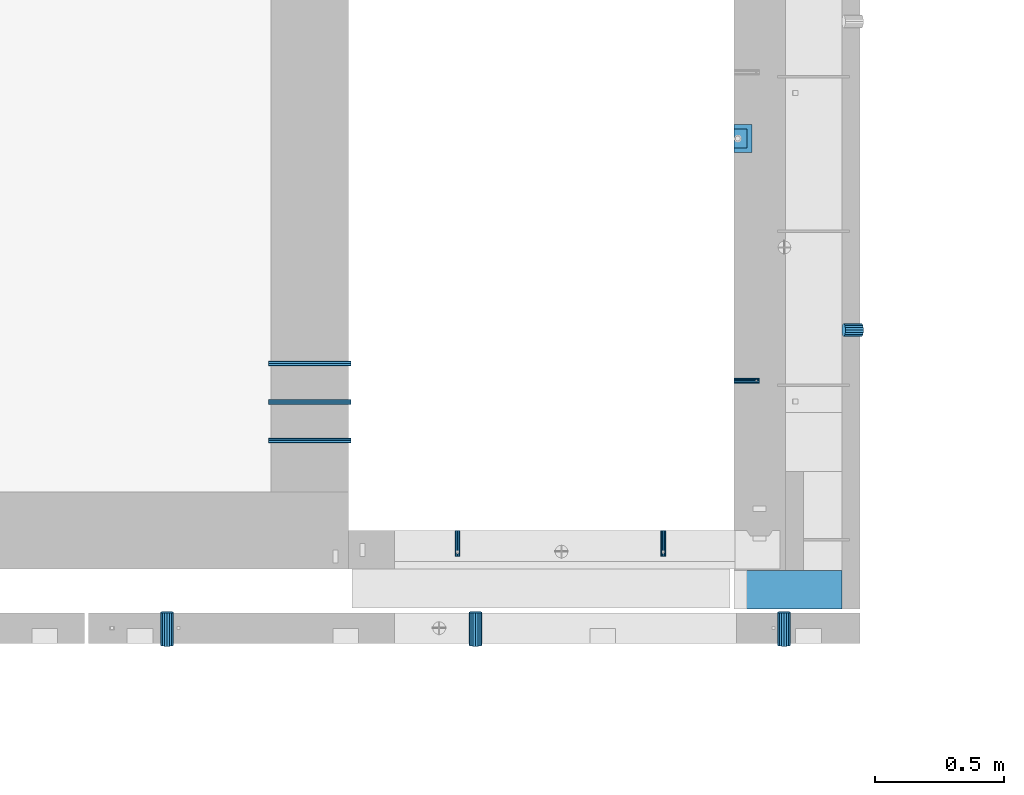
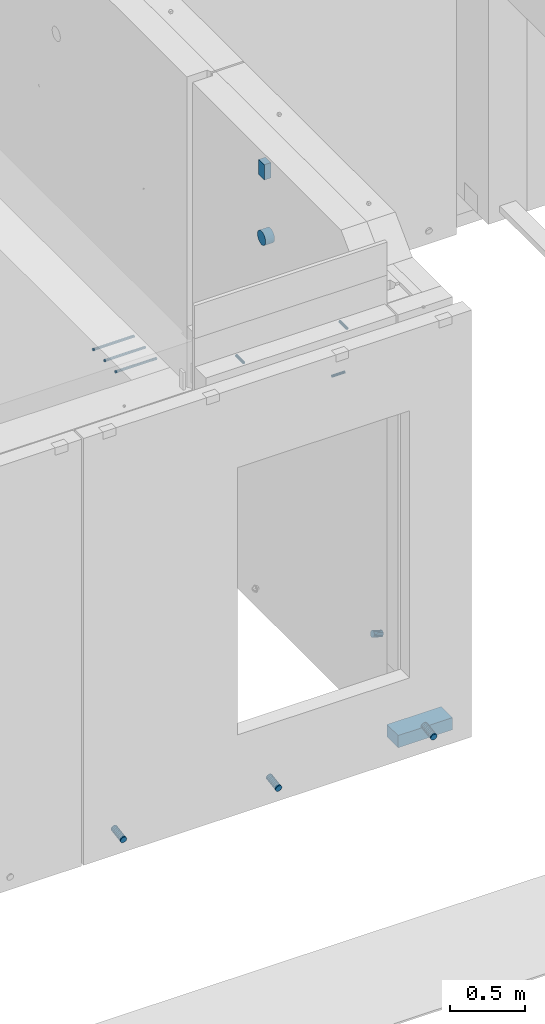
# One storey, part 89 of 264: 13 beams, 13 elements without a shape of their own.
"""IFC2X3 building model written with IfcOpenShell, lengths in millimetres."""

from ifc_helpers import new_model, si_unit, frame, origin_with_axes, place, context, subcontext, project, spatial, faceted_brep, material, type_object, element, aggregate, save


model = new_model("IFC2X3")

# Units and contexts
model_context = context("Model", 3, precision=1e-05, world=origin_with_axes())
body_context = subcontext(model_context, "Body", "Model", "MODEL_VIEW")
ifc_project = project(units=[si_unit("LENGTHUNIT", "METRE", prefix="MILLI"), si_unit("AREAUNIT", "SQUARE_METRE"), si_unit("VOLUMEUNIT", "CUBIC_METRE"), si_unit("MASSUNIT", "GRAM", prefix="KILO"), si_unit("TIMEUNIT", "SECOND"), si_unit("PLANEANGLEUNIT", "RADIAN"), si_unit("SOLIDANGLEUNIT", "STERADIAN"), si_unit("THERMODYNAMICTEMPERATUREUNIT", "DEGREE_CELSIUS"), si_unit("LUMINOUSINTENSITYUNIT", "LUMEN")], contexts=[model_context])

# Site, building, storey
site_placement = place(None, origin_with_axes())
site = spatial("IfcSite", under=ifc_project, at=site_placement, CompositionType="ELEMENT")
building_placement = place(site_placement, origin_with_axes())
building = spatial("IfcBuilding", under=site, at=building_placement, CompositionType="ELEMENT")
storey_placement = place(building_placement, origin_with_axes())
storey = spatial("IfcBuildingStorey", under=building, at=storey_placement, Name="K", CompositionType="ELEMENT", Elevation=0.0)

# Assemblies, beams
assembly_1_placement = place(storey_placement, origin_with_axes())
assembly_1 = element("IfcElementAssembly", 1, at=assembly_1_placement, inside=storey, AssemblyPlace="NOTDEFINED", PredefinedType="REINFORCEMENT_UNIT")
assembly_2_placement = place(assembly_1_placement, origin_with_axes())
assembly_2 = element("IfcElementAssembly", 2, at=assembly_2_placement, Name="Steel Assembly", AssemblyPlace="NOTDEFINED", PredefinedType="RIGID_FRAME")
ifc_material_1 = material(Name="STEEL/Steel_Undefined")
beam_type_1 = type_object("IfcBeamType", PredefinedType="NOTDEFINED")
beam_1_placement = place(assembly_2_placement, frame((17985.0020882577, 7999.99899559978, 81100.0), z_axis=(-1.0, 3.00000001838171e-08, 0.0), x_axis=(0.0, -1.0, 0.0)))
beam_1 = element("IfcBeam", 3, at=beam_1_placement, type_object=beam_type_1, material=ifc_material_1, Name="M16", context=body_context, shape_type="Brep", body=[
    faceted_brep([(0.0, -8.49999999999272, -1.45519152283669e-11), (0.0, -7.36121593215648, 4.24999999998545), (100.000000000262, -7.36121593215648, 4.24999999998545), (100.000000000262, -8.49999999999272, -1.45519152283669e-11), (0.0, -4.24999999998545, 7.36121593216376), (100.000000000262, -4.24999999998545, 7.36121593216376), (0.0, 1.45519152283669e-11, 8.49999999998545), (100.000000000262, 1.45519152283669e-11, 8.49999999998545), (0.0, 4.25000000001455, 7.36121593216376), (100.000000000262, 4.25000000001455, 7.36121593216376), (0.0, 7.36121593217104, 4.24999999998545), (100.000000000262, 7.36121593217104, 4.24999999998545), (0.0, 8.50000000000728, 0.0), (100.000000000262, 8.50000000000728, 0.0), (0.0, 7.36121593217104, -4.25000000001455), (100.000000000262, 7.36121593217104, -4.25000000001455), (0.0, 4.25000000000728, -7.36121593219286), (100.000000000262, 4.25000000000728, -7.36121593219286), (0.0, 7.27595761418343e-12, -8.5), (100.000000000262, 7.27595761418343e-12, -8.5), (0.0, -4.24999999999272, -7.36121593217831), (100.000000000262, -4.24999999999272, -7.36121593217831), (0.0, -7.36121593215648, -4.25), (100.000000000262, -7.36121593215648, -4.25), (0.0, -10.4999999999927, -1.45519152283669e-11), (0.0, -9.09326673972828, -5.25000000001455), (100.000000000262, -9.09326673972828, -5.25000000001455), (100.000000000262, -10.4999999999927, -1.45519152283669e-11), (0.0, -5.24999999998545, -9.09326673974283), (100.000000000262, -5.24999999998545, -9.09326673974283), (0.0, 7.27595761418343e-12, -10.5), (100.000000000262, 7.27595761418343e-12, -10.5), (0.0, 5.25000000001455, -9.09326673975738), (100.000000000262, 5.25000000001455, -9.09326673975738), (0.0, 9.09326673975011, -5.25000000001455), (100.000000000262, 9.09326673975011, -5.25000000001455), (0.0, 10.5000000000073, -1.45519152283669e-11), (100.000000000262, 10.5000000000073, -1.45519152283669e-11), (0.0, 9.09326673975011, 5.25), (100.000000000262, 9.09326673975011, 5.25), (0.0, 5.25000000000728, 9.09326673972828), (100.000000000262, 5.25000000000728, 9.09326673972828), (0.0, 1.45519152283669e-11, 10.4999999999854), (100.000000000262, 1.45519152283669e-11, 10.4999999999854), (0.0, -5.24999999999272, 9.09326673972828), (100.000000000262, -5.24999999999272, 9.09326673972828), (0.0, -9.09326673972828, 5.24999999998545), (100.000000000262, -9.09326673972828, 5.24999999998545)], [[[0, 1, 2, 3]], [[1, 4, 5, 2]], [[4, 6, 7, 5]], [[6, 8, 9, 7]], [[8, 10, 11, 9]], [[10, 12, 13, 11]], [[12, 14, 15, 13]], [[14, 16, 17, 15]], [[16, 18, 19, 17]], [[18, 20, 21, 19]], [[20, 22, 23, 21]], [[22, 0, 3, 23]], [[24, 25, 26, 27]], [[25, 28, 29, 26]], [[28, 30, 31, 29]], [[30, 32, 33, 31]], [[32, 34, 35, 33]], [[34, 36, 37, 35]], [[36, 38, 39, 37]], [[38, 40, 41, 39]], [[40, 42, 43, 41]], [[42, 44, 45, 43]], [[44, 46, 47, 45]], [[46, 24, 27, 47]], [[29, 31, 33, 35, 37, 39, 41, 43, 45, 47, 27, 26], [5, 7, 9, 11, 13, 15, 17, 19, 21, 23, 3, 2]], [[46, 44, 42, 40, 38, 36, 34, 32, 30, 28, 25, 24], [22, 20, 18, 16, 14, 12, 10, 8, 6, 4, 1, 0]]]),
])
aggregate(assembly_2, [beam_1])
assembly_3_placement = place(assembly_1_placement, origin_with_axes())
assembly_3 = element("IfcElementAssembly", 4, at=assembly_3_placement, Name="Steel Assembly", AssemblyPlace="NOTDEFINED", PredefinedType="RIGID_FRAME")
aggregate(assembly_1, [assembly_2, assembly_3])
beam_2_placement = place(assembly_3_placement, frame((17185.0020882577, 7999.99899559978, 81100.0), z_axis=(-1.0, 3.00000001838171e-08, 0.0), x_axis=(0.0, -1.0, 0.0)))
beam_2 = element("IfcBeam", 5, at=beam_2_placement, type_object=beam_type_1, material=ifc_material_1, Name="M16", context=body_context, shape_type="Brep", body=[
    faceted_brep([(0.0, -8.49999999999272, -1.45519152283669e-11), (0.0, -7.36121593215648, 4.24999999998545), (100.000000000262, -7.36121593215648, 4.24999999998545), (100.000000000262, -8.49999999999272, -1.45519152283669e-11), (0.0, -4.24999999998545, 7.36121593216376), (100.000000000262, -4.24999999998545, 7.36121593216376), (0.0, 1.45519152283669e-11, 8.49999999998545), (100.000000000262, 1.45519152283669e-11, 8.49999999998545), (0.0, 4.25000000001455, 7.36121593216376), (100.000000000262, 4.25000000001455, 7.36121593216376), (0.0, 7.36121593217104, 4.24999999998545), (100.000000000262, 7.36121593217104, 4.24999999998545), (0.0, 8.50000000000728, 0.0), (100.000000000262, 8.50000000000728, 0.0), (0.0, 7.36121593217104, -4.25000000001455), (100.000000000262, 7.36121593217104, -4.25000000001455), (0.0, 4.25000000000728, -7.36121593219286), (100.000000000262, 4.25000000000728, -7.36121593219286), (0.0, 7.27595761418343e-12, -8.5), (100.000000000262, 7.27595761418343e-12, -8.5), (0.0, -4.24999999999272, -7.36121593217831), (100.000000000262, -4.24999999999272, -7.36121593217831), (0.0, -7.36121593215648, -4.25), (100.000000000262, -7.36121593215648, -4.25), (0.0, -10.4999999999927, -1.45519152283669e-11), (0.0, -9.09326673972828, -5.25000000001455), (100.000000000262, -9.09326673972828, -5.25000000001455), (100.000000000262, -10.4999999999927, -1.45519152283669e-11), (0.0, -5.24999999998545, -9.09326673974283), (100.000000000262, -5.24999999998545, -9.09326673974283), (0.0, 7.27595761418343e-12, -10.5), (100.000000000262, 7.27595761418343e-12, -10.5), (0.0, 5.25000000001455, -9.09326673975738), (100.000000000262, 5.25000000001455, -9.09326673975738), (0.0, 9.09326673975011, -5.25000000001455), (100.000000000262, 9.09326673975011, -5.25000000001455), (0.0, 10.5000000000073, -1.45519152283669e-11), (100.000000000262, 10.5000000000073, -1.45519152283669e-11), (0.0, 9.09326673975011, 5.25), (100.000000000262, 9.09326673975011, 5.25), (0.0, 5.25000000000728, 9.09326673972828), (100.000000000262, 5.25000000000728, 9.09326673972828), (0.0, 1.45519152283669e-11, 10.4999999999854), (100.000000000262, 1.45519152283669e-11, 10.4999999999854), (0.0, -5.24999999999272, 9.09326673972828), (100.000000000262, -5.24999999999272, 9.09326673972828), (0.0, -9.09326673972828, 5.24999999998545), (100.000000000262, -9.09326673972828, 5.24999999998545)], [[[0, 1, 2, 3]], [[1, 4, 5, 2]], [[4, 6, 7, 5]], [[6, 8, 9, 7]], [[8, 10, 11, 9]], [[10, 12, 13, 11]], [[12, 14, 15, 13]], [[14, 16, 17, 15]], [[16, 18, 19, 17]], [[18, 20, 21, 19]], [[20, 22, 23, 21]], [[22, 0, 3, 23]], [[24, 25, 26, 27]], [[25, 28, 29, 26]], [[28, 30, 31, 29]], [[30, 32, 33, 31]], [[32, 34, 35, 33]], [[34, 36, 37, 35]], [[36, 38, 39, 37]], [[38, 40, 41, 39]], [[40, 42, 43, 41]], [[42, 44, 45, 43]], [[44, 46, 47, 45]], [[46, 24, 27, 47]], [[29, 31, 33, 35, 37, 39, 41, 43, 45, 47, 27, 26], [5, 7, 9, 11, 13, 15, 17, 19, 21, 23, 3, 2]], [[46, 44, 42, 40, 38, 36, 34, 32, 30, 28, 25, 24], [22, 20, 18, 16, 14, 12, 10, 8, 6, 4, 1, 0]]]),
])
aggregate(assembly_3, [beam_2])

# Assemblies, beam
assembly_4_placement = place(storey_placement, origin_with_axes())
assembly_4 = element("IfcElementAssembly", 6, at=assembly_4_placement, inside=storey, AssemblyPlace="NOTDEFINED", PredefinedType="REINFORCEMENT_UNIT")
assembly_5_placement = place(assembly_4_placement, origin_with_axes())
assembly_5 = element("IfcElementAssembly", 7, at=assembly_5_placement, Name="Steel Assembly", AssemblyPlace="NOTDEFINED", PredefinedType="RIGID_FRAME")
beam_3_placement = place(assembly_5_placement, frame((18260.0, 8583.09022014041, 80200.0), z_axis=(0.0, -1.0, 0.0), x_axis=(1.0, 0.0, 0.0)))
beam_3 = element("IfcBeam", 8, at=beam_3_placement, type_object=beam_type_1, material=ifc_material_1, Name="M16", context=body_context, shape_type="Brep", body=[
    faceted_brep([(0.0, -8.49999999999272, -1.45519152283669e-11), (0.0, -7.36121593215648, 4.24999999998545), (100.000000000262, -7.36121593215648, 4.24999999998545), (100.000000000262, -8.49999999999272, -1.45519152283669e-11), (0.0, -4.24999999998545, 7.36121593216376), (100.000000000262, -4.24999999998545, 7.36121593216376), (0.0, 1.45519152283669e-11, 8.49999999998545), (100.000000000262, 1.45519152283669e-11, 8.49999999998545), (0.0, 4.25000000001455, 7.36121593216376), (100.000000000262, 4.25000000001455, 7.36121593216376), (0.0, 7.36121593217104, 4.24999999998545), (100.000000000262, 7.36121593217104, 4.24999999998545), (0.0, 8.50000000000728, 0.0), (100.000000000262, 8.50000000000728, 0.0), (0.0, 7.36121593217104, -4.25000000001455), (100.000000000262, 7.36121593217104, -4.25000000001455), (0.0, 4.25000000000728, -7.36121593219286), (100.000000000262, 4.25000000000728, -7.36121593219286), (0.0, 7.27595761418343e-12, -8.5), (100.000000000262, 7.27595761418343e-12, -8.5), (0.0, -4.24999999999272, -7.36121593217831), (100.000000000262, -4.24999999999272, -7.36121593217831), (0.0, -7.36121593215648, -4.25), (100.000000000262, -7.36121593215648, -4.25), (0.0, -10.4999999999927, -1.45519152283669e-11), (0.0, -9.09326673972828, -5.25000000001455), (100.000000000262, -9.09326673972828, -5.25000000001455), (100.000000000262, -10.4999999999927, -1.45519152283669e-11), (0.0, -5.24999999998545, -9.09326673974283), (100.000000000262, -5.24999999998545, -9.09326673974283), (0.0, 7.27595761418343e-12, -10.5), (100.000000000262, 7.27595761418343e-12, -10.5), (0.0, 5.25000000001455, -9.09326673975738), (100.000000000262, 5.25000000001455, -9.09326673975738), (0.0, 9.09326673975011, -5.25000000001455), (100.000000000262, 9.09326673975011, -5.25000000001455), (0.0, 10.5000000000073, -1.45519152283669e-11), (100.000000000262, 10.5000000000073, -1.45519152283669e-11), (0.0, 9.09326673975011, 5.25), (100.000000000262, 9.09326673975011, 5.25), (0.0, 5.25000000000728, 9.09326673972828), (100.000000000262, 5.25000000000728, 9.09326673972828), (0.0, 1.45519152283669e-11, 10.4999999999854), (100.000000000262, 1.45519152283669e-11, 10.4999999999854), (0.0, -5.24999999999272, 9.09326673972828), (100.000000000262, -5.24999999999272, 9.09326673972828), (0.0, -9.09326673972828, 5.24999999998545), (100.000000000262, -9.09326673972828, 5.24999999998545)], [[[0, 1, 2, 3]], [[1, 4, 5, 2]], [[4, 6, 7, 5]], [[6, 8, 9, 7]], [[8, 10, 11, 9]], [[10, 12, 13, 11]], [[12, 14, 15, 13]], [[14, 16, 17, 15]], [[16, 18, 19, 17]], [[18, 20, 21, 19]], [[20, 22, 23, 21]], [[22, 0, 3, 23]], [[24, 25, 26, 27]], [[25, 28, 29, 26]], [[28, 30, 31, 29]], [[30, 32, 33, 31]], [[32, 34, 35, 33]], [[34, 36, 37, 35]], [[36, 38, 39, 37]], [[38, 40, 41, 39]], [[40, 42, 43, 41]], [[42, 44, 45, 43]], [[44, 46, 47, 45]], [[46, 24, 27, 47]], [[29, 31, 33, 35, 37, 39, 41, 43, 45, 47, 27, 26], [5, 7, 9, 11, 13, 15, 17, 19, 21, 23, 3, 2]], [[46, 44, 42, 40, 38, 36, 34, 32, 30, 28, 25, 24], [22, 20, 18, 16, 14, 12, 10, 8, 6, 4, 1, 0]]]),
])
aggregate(assembly_5, [beam_3])

# Assembly, beam
assembly_6_placement = place(storey_placement, origin_with_axes())
assembly_6 = element("IfcElementAssembly", 9, at=assembly_6_placement, inside=storey, Name="Steel Assembly", AssemblyPlace="NOTDEFINED", PredefinedType="NOTDEFINED")
ifc_material_2 = material()
beam_type_2 = type_object("IfcBeamType", Name="D20", PredefinedType="NOTDEFINED")
beam_4_placement = place(assembly_6_placement, frame((16450.0002273917, 8650.0001129508, 81010.0), z_axis=(0.0, 0.0, 1.0), x_axis=(1.0, 0.0, 0.0)))
beam_4 = element("IfcBeam", 10, at=beam_4_placement, type_object=beam_type_2, material=ifc_material_2, ObjectType="D20", context=body_context, shape_type="Brep", body=[
    faceted_brep([(0.0, -10.0, 0.0), (-4.19531716033816e-08, -7.07106781186667, -7.07106781187031), (320.000093691564, -7.07106781186485, -7.07106781186303), (320.000093691564, -10.0, 0.0), (0.0, 0.0, -10.0), (320.000093691564, 0.0, -10.0), (4.196772351861e-08, 7.07106781186303, -7.07106781186667), (320.000093691564, 7.07106781186485, -7.07106781186303), (0.0, 10.0, 0.0), (320.000093691564, 10.0, 0.0), (4.196772351861e-08, 7.07106781185939, 7.07106781185939), (320.000093691564, 7.07106781186485, 7.07106781186303), (0.0, 0.0, 10.0), (320.000093691564, 0.0, 10.0), (-4.19531716033816e-08, -7.07106781187031, 7.07106781185939), (320.000093691564, -7.07106781186485, 7.07106781186303)], [[[0, 1, 2, 3]], [[1, 4, 5, 2]], [[4, 6, 7, 5]], [[6, 8, 9, 7]], [[8, 10, 11, 9]], [[10, 12, 13, 11]], [[12, 14, 15, 13]], [[14, 0, 3, 15]], [[5, 7, 9, 11, 13, 15, 3, 2]], [[14, 12, 10, 8, 6, 4, 1, 0]]]),
])
aggregate(assembly_6, [beam_4])

assembly_7_placement = place(storey_placement, origin_with_axes())
assembly_7 = element("IfcElementAssembly", 11, at=assembly_7_placement, inside=storey, Name="Steel Assembly", AssemblyPlace="NOTDEFINED", PredefinedType="NOTDEFINED")
beam_5_placement = place(assembly_7_placement, frame((16450.0002273917, 8500.0001129508, 81010.0), z_axis=(0.0, 0.0, 1.0), x_axis=(1.0, 0.0, 0.0)))
beam_5 = element("IfcBeam", 12, at=beam_5_placement, type_object=beam_type_2, material=ifc_material_2, ObjectType="D20", context=body_context, shape_type="Brep", body=[
    faceted_brep([(0.0, -10.0, 0.0), (-4.19531716033816e-08, -7.07106781186667, -7.07106781187031), (320.000093691564, -7.07106781186485, -7.07106781186303), (320.000093691564, -10.0, 0.0), (0.0, 0.0, -10.0), (320.000093691564, 0.0, -10.0), (4.196772351861e-08, 7.07106781186303, -7.07106781186667), (320.000093691564, 7.07106781186485, -7.07106781186303), (0.0, 10.0, 0.0), (320.000093691564, 10.0, 0.0), (4.196772351861e-08, 7.07106781185939, 7.07106781185939), (320.000093691564, 7.07106781186485, 7.07106781186303), (0.0, 0.0, 10.0), (320.000093691564, 0.0, 10.0), (-4.19531716033816e-08, -7.07106781187031, 7.07106781185939), (320.000093691564, -7.07106781186485, 7.07106781186303)], [[[0, 1, 2, 3]], [[1, 4, 5, 2]], [[4, 6, 7, 5]], [[6, 8, 9, 7]], [[8, 10, 11, 9]], [[10, 12, 13, 11]], [[12, 14, 15, 13]], [[14, 0, 3, 15]], [[5, 7, 9, 11, 13, 15, 3, 2]], [[14, 12, 10, 8, 6, 4, 1, 0]]]),
])
aggregate(assembly_7, [beam_5])

assembly_8_placement = place(storey_placement, origin_with_axes())
assembly_8 = element("IfcElementAssembly", 13, at=assembly_8_placement, inside=storey, Name="Steel Assembly", AssemblyPlace="NOTDEFINED", PredefinedType="NOTDEFINED")
beam_6_placement = place(assembly_8_placement, frame((16450.0002273917, 8350.0001129508, 81010.0), z_axis=(0.0, 0.0, 1.0), x_axis=(1.0, 0.0, 0.0)))
beam_6 = element("IfcBeam", 14, at=beam_6_placement, type_object=beam_type_2, material=ifc_material_2, ObjectType="D20", context=body_context, shape_type="Brep", body=[
    faceted_brep([(0.0, -10.0, 0.0), (-4.19531716033816e-08, -7.07106781186667, -7.07106781187031), (320.000093691564, -7.07106781186485, -7.07106781186303), (320.000093691564, -10.0, 0.0), (0.0, 0.0, -10.0), (320.000093691564, 0.0, -10.0), (4.196772351861e-08, 7.07106781186303, -7.07106781186667), (320.000093691564, 7.07106781186485, -7.07106781186303), (0.0, 10.0, 0.0), (320.000093691564, 10.0, 0.0), (4.196772351861e-08, 7.07106781185939, 7.07106781185939), (320.000093691564, 7.07106781186485, 7.07106781186303), (0.0, 0.0, 10.0), (320.000093691564, 0.0, 10.0), (-4.19531716033816e-08, -7.07106781187031, 7.07106781185939), (320.000093691564, -7.07106781186485, 7.07106781186303)], [[[0, 1, 2, 3]], [[1, 4, 5, 2]], [[4, 6, 7, 5]], [[6, 8, 9, 7]], [[8, 10, 11, 9]], [[10, 12, 13, 11]], [[12, 14, 15, 13]], [[14, 0, 3, 15]], [[5, 7, 9, 11, 13, 15, 3, 2]], [[14, 12, 10, 8, 6, 4, 1, 0]]]),
])
aggregate(assembly_8, [beam_6])

# Beam
ifc_material_3 = material()
beam_type_3 = type_object("IfcBeamType", Name="D110", PredefinedType="NOTDEFINED")
beam_7_placement = place(assembly_4_placement, frame((18260.0, 9525.00030504026, 80760.0), z_axis=(0.0, 0.0, 1.0), x_axis=(1.0, 0.0, 0.0)))
beam_7 = element("IfcBeam", 15, at=beam_7_placement, type_object=beam_type_3, material=ifc_material_3, ObjectType="D110", context=body_context, shape_type="Brep", body=[
    faceted_brep([(0.0, -55.0, 0.0), (0.0, -52.3081083962352, -16.9959346906253), (70.0, -52.3081083962352, -16.9959346906253), (70.0, -55.0, 0.0), (0.0, -44.4959346906217, -32.328188876083), (70.0, -44.4959346906217, -32.328188876083), (0.0, -32.3281888760866, -44.4959346906253), (70.0, -32.3281888760866, -44.4959346906253), (0.0, -16.9959346906217, -52.3081083962315), (70.0, -16.9959346906217, -52.3081083962315), (0.0, 0.0, -55.0), (70.0, 0.0, -55.0), (0.0, 16.9959346906217, -52.3081083962315), (70.0, 16.9959346906217, -52.3081083962315), (0.0, 32.3281888760866, -44.4959346906253), (70.0, 32.3281888760866, -44.4959346906253), (0.0, 44.4959346906217, -32.328188876083), (70.0, 44.4959346906217, -32.328188876083), (0.0, 52.3081083962352, -16.9959346906253), (70.0, 52.3081083962352, -16.9959346906253), (0.0, 55.0, 0.0), (70.0, 55.0, 0.0), (0.0, 52.3081083962352, 16.9959346906253), (70.0, 52.3081083962352, 16.9959346906253), (0.0, 44.4959346906217, 32.328188876083), (70.0, 44.4959346906217, 32.328188876083), (0.0, 32.3281888760866, 44.4959346906253), (70.0, 32.3281888760866, 44.4959346906253), (0.0, 16.9959346906217, 52.3081083962315), (70.0, 16.9959346906217, 52.3081083962315), (0.0, 0.0, 55.0), (70.0, 0.0, 55.0), (0.0, -16.9959346906217, 52.3081083962315), (70.0, -16.9959346906217, 52.3081083962315), (0.0, -32.3281888760866, 44.4959346906253), (70.0, -32.3281888760866, 44.4959346906253), (0.0, -44.4959346906217, 32.328188876083), (70.0, -44.4959346906217, 32.328188876083), (0.0, -52.3081083962352, 16.9959346906253), (70.0, -52.3081083962352, 16.9959346906253)], [[[0, 1, 2, 3]], [[1, 4, 5, 2]], [[4, 6, 7, 5]], [[6, 8, 9, 7]], [[8, 10, 11, 9]], [[10, 12, 13, 11]], [[12, 14, 15, 13]], [[14, 16, 17, 15]], [[16, 18, 19, 17]], [[18, 20, 21, 19]], [[20, 22, 23, 21]], [[22, 24, 25, 23]], [[24, 26, 27, 25]], [[26, 28, 29, 27]], [[28, 30, 31, 29]], [[30, 32, 33, 31]], [[32, 34, 35, 33]], [[34, 36, 37, 35]], [[36, 38, 39, 37]], [[38, 0, 3, 39]], [[5, 7, 9, 11, 13, 15, 17, 19, 21, 23, 25, 27, 29, 31, 33, 35, 37, 39, 3, 2]], [[38, 36, 34, 32, 30, 28, 26, 24, 22, 20, 18, 16, 14, 12, 10, 8, 6, 4, 1, 0]]]),
])

beam_type_4 = type_object("IfcBeamType", Name="125X50", PredefinedType="NOTDEFINED")
beam_8_placement = place(assembly_4_placement, frame((18285.0, 9487.50202507202, 81317.5), z_axis=(0.0, 0.0, 1.0), x_axis=(0.0, 1.0, 0.0)))
beam_8 = element("IfcBeam", 16, at=beam_8_placement, type_object=beam_type_4, material=ifc_material_3, Name="WM1", ObjectType="125X50", context=body_context, shape_type="Brep", body=[
    faceted_brep([(0.0, 25.0, -62.5), (0.0, 25.0, 62.5), (75.0, 25.0, 62.5), (75.0, 25.0, -62.5), (0.0, -25.0, 62.5), (75.0, -25.0, 62.5), (0.0, -25.0, -62.5), (75.0, -25.0, -62.5)], [[[0, 1, 2, 3]], [[1, 4, 5, 2]], [[4, 6, 7, 5]], [[6, 0, 3, 7]], [[5, 7, 3, 2]], [[0, 6, 4, 1]]]),
])

# Assemblies, beams
assembly_9_placement = place(storey_placement, origin_with_axes())
assembly_9 = element("IfcElementAssembly", 17, at=assembly_9_placement, inside=storey, AssemblyPlace="NOTDEFINED", PredefinedType="REINFORCEMENT_UNIT")
assembly_10_placement = place(assembly_9_placement, origin_with_axes())
assembly_10 = element("IfcElementAssembly", 18, at=assembly_10_placement, Name="Steel Assembly", AssemblyPlace="NOTDEFINED", PredefinedType="NOTDEFINED")
ifc_material_4 = material()
beam_type_5 = type_object("IfcBeamType", Name="D50", PredefinedType="NOTDEFINED")
beam_9_placement = place(assembly_10_placement, frame((18455.0000002562, 7682.52585845164, 77824.7042173487), z_axis=(1.0, 0.0, 0.0), x_axis=(5.70000016371802e-08, -0.988168693923421, -0.1533708979881)))
beam_9 = element("IfcBeam", 19, at=beam_9_placement, type_object=beam_type_5, material=ifc_material_4, ObjectType="D50", context=body_context, shape_type="Brep", body=[
    faceted_brep([(0.0, -25.0, 0.0), (-3.63797880709171e-12, -23.0969883127837, -9.56708580912891), (130.402835998197, -23.0969883127691, -9.56708580912164), (130.402836001198, -25.0, 0.0), (-3.63797880709171e-12, -17.6776695296576, -17.6776695296649), (130.402835995654, -17.6776695296576, -17.6776695296612), (-1.09139364212751e-11, -9.56708580913255, -23.0969883127837), (130.402835993955, -9.567085809118, -23.0969883127764), (-1.09139364212751e-11, 0.0, -25.0), (130.402835993358, 0.0, -24.9999999999964), (-1.09139364212751e-11, 9.56708580913255, -23.0969883127837), (130.402835993951, 9.56708580913255, -23.09698831278), (-3.63797880709171e-12, 17.6776695296576, -17.6776695296649), (130.402835995654, 17.6776695296721, -17.6776695296612), (-3.63797880709171e-12, 23.0969883127837, -9.56708580912891), (130.402835998197, 23.0969883127837, -9.56708580912527), (0.0, 25.0, 0.0), (130.402836001202, 25.0, 7.27595761418343e-12), (7.27595761418343e-12, 23.0969883127837, 9.56708580912891), (130.402836004203, 23.0969883127982, 9.56708580913255), (7.27595761418343e-12, 17.6776695296576, 17.6776695296649), (130.402836006746, 17.6776695296721, 17.6776695296685), (1.45519152283669e-11, 9.56708580913255, 23.0969883127837), (130.402836008445, 9.56708580913255, 23.0969883127837), (1.09139364212751e-11, 0.0, 25.0), (130.402836009045, 1.45519152283669e-11, 25.0000000000036), (1.45519152283669e-11, -9.56708580913255, 23.0969883127837), (130.402836008449, -9.567085809118, 23.0969883127873), (7.27595761418343e-12, -17.6776695296576, 17.6776695296649), (130.402836006746, -17.6776695296576, 17.6776695296685), (7.27595761418343e-12, -23.0969883127837, 9.56708580912891), (130.402836004199, -23.0969883127837, 9.56708580913255)], [[[0, 1, 2, 3]], [[1, 4, 5, 2]], [[4, 6, 7, 5]], [[6, 8, 9, 7]], [[8, 10, 11, 9]], [[10, 12, 13, 11]], [[12, 14, 15, 13]], [[14, 16, 17, 15]], [[16, 18, 19, 17]], [[18, 20, 21, 19]], [[20, 22, 23, 21]], [[22, 24, 25, 23]], [[24, 26, 27, 25]], [[26, 28, 29, 27]], [[28, 30, 31, 29]], [[30, 0, 3, 31]], [[5, 7, 9, 11, 13, 15, 17, 19, 21, 23, 25, 27, 29, 31, 3, 2]], [[30, 28, 26, 24, 22, 20, 18, 16, 14, 12, 10, 8, 6, 4, 1, 0]]]),
])
aggregate(assembly_10, [beam_9])
assembly_11_placement = place(assembly_9_placement, origin_with_axes())
assembly_11 = element("IfcElementAssembly", 20, at=assembly_11_placement, Name="Steel Assembly", AssemblyPlace="NOTDEFINED", PredefinedType="NOTDEFINED")
beam_10_placement = place(assembly_11_placement, frame((16055.0000002562, 7682.52585845164, 77824.7042173487), z_axis=(1.0, 0.0, 0.0), x_axis=(5.70000016371802e-08, -0.988168693923421, -0.1533708979881)))
beam_10 = element("IfcBeam", 21, at=beam_10_placement, type_object=beam_type_5, material=ifc_material_4, ObjectType="D50", context=body_context, shape_type="Brep", body=[
    faceted_brep([(0.0, -25.0, 0.0), (-3.63797880709171e-12, -23.0969883127837, -9.56708580912891), (130.402835998197, -23.0969883127691, -9.56708580912164), (130.402836001198, -25.0, 0.0), (-3.63797880709171e-12, -17.6776695296576, -17.6776695296649), (130.402835995654, -17.6776695296576, -17.6776695296612), (-1.09139364212751e-11, -9.56708580913255, -23.0969883127837), (130.402835993955, -9.567085809118, -23.0969883127764), (-1.09139364212751e-11, 0.0, -25.0), (130.402835993358, 0.0, -24.9999999999964), (-1.09139364212751e-11, 9.56708580913255, -23.0969883127837), (130.402835993951, 9.56708580913255, -23.09698831278), (-3.63797880709171e-12, 17.6776695296576, -17.6776695296649), (130.402835995654, 17.6776695296721, -17.6776695296612), (-3.63797880709171e-12, 23.0969883127837, -9.56708580912891), (130.402835998197, 23.0969883127837, -9.56708580912527), (0.0, 25.0, 0.0), (130.402836001202, 25.0, 7.27595761418343e-12), (7.27595761418343e-12, 23.0969883127837, 9.56708580912891), (130.402836004203, 23.0969883127982, 9.56708580913255), (7.27595761418343e-12, 17.6776695296576, 17.6776695296649), (130.402836006746, 17.6776695296721, 17.6776695296685), (1.45519152283669e-11, 9.56708580913255, 23.0969883127837), (130.402836008445, 9.56708580913255, 23.0969883127837), (1.09139364212751e-11, 0.0, 25.0), (130.402836009045, 1.45519152283669e-11, 25.0000000000036), (1.45519152283669e-11, -9.56708580913255, 23.0969883127837), (130.402836008449, -9.567085809118, 23.0969883127873), (7.27595761418343e-12, -17.6776695296576, 17.6776695296649), (130.402836006746, -17.6776695296576, 17.6776695296685), (7.27595761418343e-12, -23.0969883127837, 9.56708580912891), (130.402836004199, -23.0969883127837, 9.56708580913255)], [[[0, 1, 2, 3]], [[1, 4, 5, 2]], [[4, 6, 7, 5]], [[6, 8, 9, 7]], [[8, 10, 11, 9]], [[10, 12, 13, 11]], [[12, 14, 15, 13]], [[14, 16, 17, 15]], [[16, 18, 19, 17]], [[18, 20, 21, 19]], [[20, 22, 23, 21]], [[22, 24, 25, 23]], [[24, 26, 27, 25]], [[26, 28, 29, 27]], [[28, 30, 31, 29]], [[30, 0, 3, 31]], [[5, 7, 9, 11, 13, 15, 17, 19, 21, 23, 25, 27, 29, 31, 3, 2]], [[30, 28, 26, 24, 22, 20, 18, 16, 14, 12, 10, 8, 6, 4, 1, 0]]]),
])
aggregate(assembly_11, [beam_10])
assembly_12_placement = place(assembly_9_placement, origin_with_axes())
assembly_12 = element("IfcElementAssembly", 22, at=assembly_12_placement, Name="Steel Assembly", AssemblyPlace="NOTDEFINED", PredefinedType="NOTDEFINED")
aggregate(assembly_9, [assembly_10, assembly_11, assembly_12])
beam_11_placement = place(assembly_12_placement, frame((17255.0000002562, 7682.52585845164, 77824.7042173487), z_axis=(1.0, 0.0, 0.0), x_axis=(5.70000016371802e-08, -0.988168693923421, -0.1533708979881)))
beam_11 = element("IfcBeam", 23, at=beam_11_placement, type_object=beam_type_5, material=ifc_material_4, ObjectType="D50", context=body_context, shape_type="Brep", body=[
    faceted_brep([(0.0, -25.0, 0.0), (-3.63797880709171e-12, -23.0969883127837, -9.56708580912891), (130.402835998197, -23.0969883127691, -9.56708580912164), (130.402836001198, -25.0, 0.0), (-3.63797880709171e-12, -17.6776695296576, -17.6776695296649), (130.402835995654, -17.6776695296576, -17.6776695296612), (-1.09139364212751e-11, -9.56708580913255, -23.0969883127837), (130.402835993955, -9.567085809118, -23.0969883127764), (-1.09139364212751e-11, 0.0, -25.0), (130.402835993358, 0.0, -24.9999999999964), (-1.09139364212751e-11, 9.56708580913255, -23.0969883127837), (130.402835993951, 9.56708580913255, -23.09698831278), (-3.63797880709171e-12, 17.6776695296576, -17.6776695296649), (130.402835995654, 17.6776695296721, -17.6776695296612), (-3.63797880709171e-12, 23.0969883127837, -9.56708580912891), (130.402835998197, 23.0969883127837, -9.56708580912527), (0.0, 25.0, 0.0), (130.402836001202, 25.0, 7.27595761418343e-12), (7.27595761418343e-12, 23.0969883127837, 9.56708580912891), (130.402836004203, 23.0969883127982, 9.56708580913255), (7.27595761418343e-12, 17.6776695296576, 17.6776695296649), (130.402836006746, 17.6776695296721, 17.6776695296685), (1.45519152283669e-11, 9.56708580913255, 23.0969883127837), (130.402836008445, 9.56708580913255, 23.0969883127837), (1.09139364212751e-11, 0.0, 25.0), (130.402836009045, 1.45519152283669e-11, 25.0000000000036), (1.45519152283669e-11, -9.56708580913255, 23.0969883127837), (130.402836008449, -9.567085809118, 23.0969883127873), (7.27595761418343e-12, -17.6776695296576, 17.6776695296649), (130.402836006746, -17.6776695296576, 17.6776695296685), (7.27595761418343e-12, -23.0969883127837, 9.56708580912891), (130.402836004199, -23.0969883127837, 9.56708580913255)], [[[0, 1, 2, 3]], [[1, 4, 5, 2]], [[4, 6, 7, 5]], [[6, 8, 9, 7]], [[8, 10, 11, 9]], [[10, 12, 13, 11]], [[12, 14, 15, 13]], [[14, 16, 17, 15]], [[16, 18, 19, 17]], [[18, 20, 21, 19]], [[20, 22, 23, 21]], [[22, 24, 25, 23]], [[24, 26, 27, 25]], [[26, 28, 29, 27]], [[28, 30, 31, 29]], [[30, 0, 3, 31]], [[5, 7, 9, 11, 13, 15, 17, 19, 21, 23, 25, 27, 29, 31, 3, 2]], [[30, 28, 26, 24, 22, 20, 18, 16, 14, 12, 10, 8, 6, 4, 1, 0]]]),
])
aggregate(assembly_12, [beam_11])

# Assembly, beam
assembly_13_placement = place(assembly_4_placement, origin_with_axes())
assembly_13 = element("IfcElementAssembly", 24, at=assembly_13_placement, Name="Steel Assembly", AssemblyPlace="NOTDEFINED", PredefinedType="NOTDEFINED")
beam_12_placement = place(assembly_13_placement, frame((18686.8680281974, 8780.00189658511, 77824.0380986928), z_axis=(0.0, 1.0, 0.0), x_axis=(0.961523947640827, 0.0, -0.274721127897365)))
beam_12 = element("IfcBeam", 25, at=beam_12_placement, type_object=beam_type_5, material=ifc_material_4, ObjectType="D50", context=body_context, shape_type="Brep", body=[
    faceted_brep([(0.0, -25.0, 0.0), (-3.63797880709171e-12, -23.0969883127837, -9.56708580912891), (72.8010988927999, -23.0969883127982, -9.56708580912891), (72.8010988927999, -25.0, 0.0), (-3.63797880709171e-12, -17.6776695296576, -17.6776695296649), (72.8010988927927, -17.6776695296576, -17.6776695296649), (-1.09139364212751e-11, -9.56708580913255, -23.0969883127837), (72.8010988927927, -9.56708580913255, -23.0969883127837), (-1.09139364212751e-11, 0.0, -25.0), (72.8010988927927, 0.0, -25.0), (-1.09139364212751e-11, 9.56708580913255, -23.0969883127837), (72.8010988927999, 9.56708580913255, -23.0969883127837), (-3.63797880709171e-12, 17.6776695296576, -17.6776695296649), (72.8010988927999, 17.6776695296721, -17.6776695296649), (-3.63797880709171e-12, 23.0969883127837, -9.56708580912891), (72.8010988927999, 23.0969883127837, -9.56708580912891), (0.0, 25.0, 0.0), (72.8010988927999, 25.0, 0.0), (7.27595761418343e-12, 23.0969883127837, 9.56708580912891), (72.8010988927999, 23.0969883127837, 9.56708580912891), (7.27595761418343e-12, 17.6776695296576, 17.6776695296649), (72.8010988927999, 17.6776695296721, 17.6776695296649), (1.45519152283669e-11, 9.56708580913255, 23.0969883127837), (72.8010988927999, 9.56708580913255, 23.0969883127837), (1.09139364212751e-11, 0.0, 25.0), (72.8010988927927, 0.0, 25.0), (1.45519152283669e-11, -9.56708580913255, 23.0969883127837), (72.8010988927927, -9.56708580913255, 23.0969883127837), (7.27595761418343e-12, -17.6776695296576, 17.6776695296649), (72.8010988927927, -17.6776695296576, 17.6776695296649), (7.27595761418343e-12, -23.0969883127837, 9.56708580912891), (72.8010988927999, -23.0969883127982, 9.56708580912891)], [[[0, 1, 2, 3]], [[1, 4, 5, 2]], [[4, 6, 7, 5]], [[6, 8, 9, 7]], [[8, 10, 11, 9]], [[10, 12, 13, 11]], [[12, 14, 15, 13]], [[14, 16, 17, 15]], [[16, 18, 19, 17]], [[18, 20, 21, 19]], [[20, 22, 23, 21]], [[22, 24, 25, 23]], [[24, 26, 27, 25]], [[26, 28, 29, 27]], [[28, 30, 31, 29]], [[30, 0, 3, 31]], [[5, 7, 9, 11, 13, 15, 17, 19, 21, 23, 25, 27, 29, 31, 3, 2]], [[30, 28, 26, 24, 22, 20, 18, 16, 14, 12, 10, 8, 6, 4, 1, 0]]]),
])
aggregate(assembly_13, [beam_12])

# Beam
ifc_material_5 = material(Name="CONCRETE/C25/30")
beam_type_6 = type_object("IfcBeamType", PredefinedType="NOTDEFINED")
beam_13_placement = place(assembly_4_placement, frame((18680.0003386759, 7770.00189658553, 77750.0), z_axis=(0.0, 0.0, 1.0), x_axis=(-0.999999999989803, -4.51600000073913e-06, 0.0)))
beam_13 = element("IfcBeam", 26, at=beam_13_placement, type_object=beam_type_6, material=ifc_material_5, context=body_context, shape_type="Brep", body=[
    faceted_brep([(0.0, 75.0, -50.0), (0.0, 75.0, 50.0), (420.000000004708, 75.0, 50.0), (420.000000004708, 75.0, -50.0), (-3.63797880709171e-12, -75.0, 50.0), (420.000000004708, -75.0, 50.0), (-3.63797880709171e-12, -75.0, -50.0), (420.000000004708, -75.0, -50.0)], [[[0, 1, 2, 3]], [[1, 4, 5, 2]], [[4, 6, 7, 5]], [[6, 0, 3, 7]], [[5, 7, 3, 2]], [[6, 4, 1, 0]]]),
])

aggregate(assembly_4, [beam_13, beam_8, beam_7, assembly_5, assembly_13])

save(model, "model.ifc")
